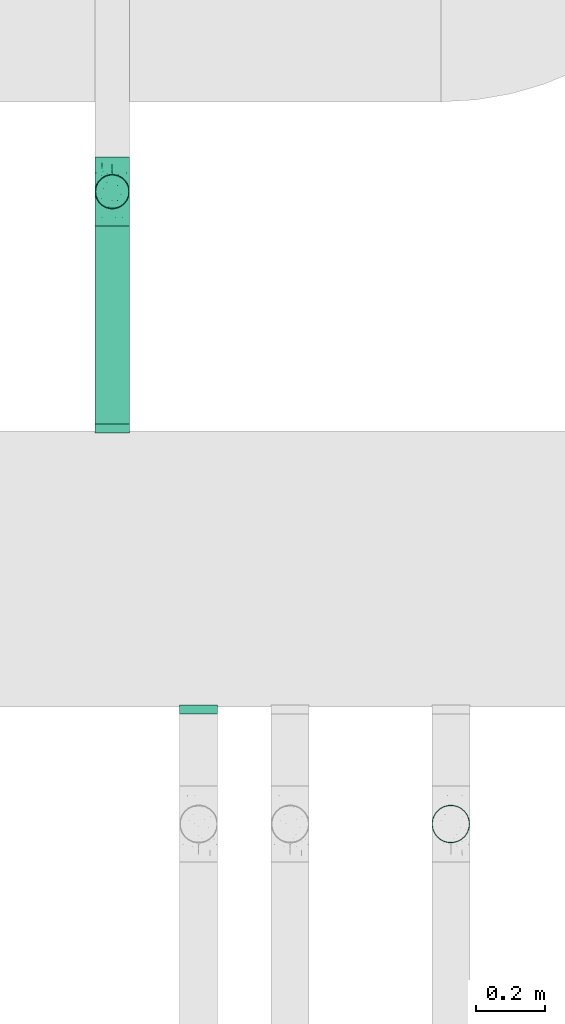
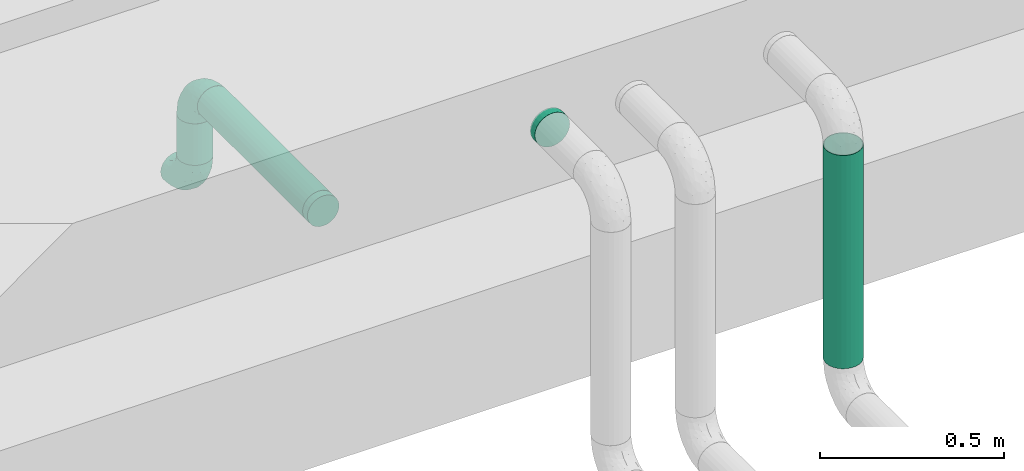
# One storey, part 57 of 91: 4 flow fittings, 3 flow segments.
"""IFC2X3 building model written with IfcOpenShell, lengths in millimetres."""

import ifcopenshell
import ifcopenshell.guid

model = None  # the IFC model being written
_history = None  # IfcOwnerHistory: only IFC2X3 demands one
_inside = {}  # id of a spatial element -> (the spatial element, [elements in it])
_under = {}  # id of a project, library or spatial element -> (it, [spatial elements below it])
_declared = {}  # id of a project -> (the project, [libraries it declares])
_typed = {}  # id of a type object -> (the type object, [elements of that type])
_made_of = {}  # id of a material, layer set ... -> (it, [elements and type objects made of it])


def new_model(schema):
    """Start an empty IFC model of exactly this schema.

    Asked for "IFC4X3", IfcOpenShell would pick the latest addendum, in which some entities
    have other attributes; the version numbers below select the first issue.
    IFC2X3 requires an IfcOwnerHistory on every rooted entity: one is made here for all.
    """
    global model, _history
    if schema == "IFC4X3":
        model = ifcopenshell.file(schema_version=(4, 3, 0, 0))
    else:
        model = ifcopenshell.file(schema=schema)
    _inside.clear()
    _under.clear()
    _declared.clear()
    _typed.clear()
    _made_of.clear()
    _history = None
    if model.schema == "IFC2X3":
        org = make("IfcOrganization", Name="unknown")
        user = make(
            "IfcPersonAndOrganization",
            ThePerson=make("IfcPerson", FamilyName="unknown"),
            TheOrganization=org,
        )
        app = make(
            "IfcApplication",
            ApplicationDeveloper=org,
            Version="unknown",
            ApplicationFullName="unknown",
            ApplicationIdentifier="unknown",
        )
        _history = make(
            "IfcOwnerHistory",
            OwningUser=user,
            OwningApplication=app,
            ChangeAction="ADDED",
            CreationDate=0,
        )
    return model


def make(cls, **values):
    """One entity of the class cls with the attributes given. An attribute that is None is left unset."""
    return model.create_entity(
        cls, **{name: value for name, value in values.items() if value is not None}
    )


def entity(cls, *values):
    """Any entity or typed value of the class cls, its attributes in the order of the schema. None: left unset."""
    e = model.create_entity(cls)
    for i, value in enumerate(values):
        if value is not None:
            e[i] = value
    return e


def rooted(cls, **values):
    """An entity with a GlobalId (a new one), such as an element, a storey or a relation."""
    return make(cls, GlobalId=ifcopenshell.guid.new(), OwnerHistory=_history, **values)


def si_unit(unit_type, name, prefix=None):
    """IfcSIUnit, for example si_unit("LENGTHUNIT", "METRE", prefix="MILLI")."""
    return make("IfcSIUnit", UnitType=unit_type, Prefix=prefix, Name=name)


def converted_unit(unit_type, name, factor, base, dimensions=None, offset=None):
    """IfcConversionBasedUnit, such as the inch: factor (a typed value) times the base unit."""
    return make(
        "IfcConversionBasedUnit"
        if offset is None
        else "IfcConversionBasedUnitWithOffset",
        ConversionOffset=offset,
        Dimensions=None
        if dimensions is None
        else entity("IfcDimensionalExponents", *dimensions),
        UnitType=unit_type,
        Name=name,
        ConversionFactor=make(
            "IfcMeasureWithUnit", ValueComponent=factor, UnitComponent=base
        ),
    )


def derived_unit(unit_type, elements):
    """IfcDerivedUnit: a product of units, each with its exponent."""
    return make(
        "IfcDerivedUnit",
        Elements=[
            make("IfcDerivedUnitElement", Unit=unit, Exponent=power)
            for unit, power in elements
        ],
        UnitType=unit_type,
    )


def assignment(units):
    """IfcUnitAssignment: the units of a project."""
    return None if units is None else make("IfcUnitAssignment", Units=units)


def point(xyz):
    """IfcCartesianPoint."""
    return None if xyz is None else make("IfcCartesianPoint", Coordinates=xyz)


def direction(xyz):
    """IfcDirection."""
    return None if xyz is None else make("IfcDirection", DirectionRatios=xyz)


def frame(location, z_axis=None, x_axis=None):
    """IfcAxis2Placement3D, a coordinate frame: its origin and axes. An axis left out is left unset."""
    return make(
        "IfcAxis2Placement3D",
        Location=point(location),
        Axis=direction(z_axis),
        RefDirection=direction(x_axis),
    )


def frame_2d(location, x_axis=None):
    """IfcAxis2Placement2D, a coordinate frame in the plane: its origin and x axis."""
    return make(
        "IfcAxis2Placement2D", Location=point(location), RefDirection=direction(x_axis)
    )


def origin_with_axes():
    """The frame at (0, 0, 0) with the z axis (0, 0, 1) and the x axis (1, 0, 0) written out."""
    return frame((0.0, 0.0, 0.0), z_axis=(0.0, 0.0, 1.0), x_axis=(1.0, 0.0, 0.0))


def origin_2d_with_axis():
    """The frame at (0, 0) in the plane with the x axis (1, 0) written out."""
    return frame_2d((0.0, 0.0), x_axis=(1.0, 0.0))


def place(relative_to, where):
    """IfcLocalPlacement: puts the frame where relative to a parent placement (None: the world)."""
    return make(
        "IfcLocalPlacement", PlacementRelTo=relative_to, RelativePlacement=where
    )


def context(
    kind, dimensions, precision=None, world=None, true_north=None, identifier=None
):
    """IfcGeometricRepresentationContext, for example the 3D "Model" context."""
    return make(
        "IfcGeometricRepresentationContext",
        ContextIdentifier=identifier,
        ContextType=kind,
        CoordinateSpaceDimension=dimensions,
        Precision=precision,
        WorldCoordinateSystem=world,
        TrueNorth=true_north,
    )


def subcontext(parent, identifier, kind, view, scale=None):
    """IfcGeometricRepresentationSubContext, for example "Body" below "Model"."""
    return make(
        "IfcGeometricRepresentationSubContext",
        ContextIdentifier=identifier,
        ContextType=kind,
        ParentContext=parent,
        TargetScale=scale,
        TargetView=view,
    )


def project(units=None, contexts=None):
    """IfcProject with its units and contexts."""
    return rooted(
        "IfcProject",
        Name="project",
        RepresentationContexts=contexts,
        UnitsInContext=assignment(units),
    )


def spatial(cls, under=None, at=None, **own):
    """A site, building, storey or space (cls), placed at a placement, below another one or the project."""
    s = rooted(cls, ObjectPlacement=at, **own)
    if under is not None:
        _under.setdefault(under.id(), (under, []))[1].append(s)
    return s


def profile(cls, at=None, kind="AREA", **sizes):
    """A parametric profile (cls). Its sizes go by their IFC names, for example OverallWidth=200.0."""
    return make(cls, ProfileType=kind, Position=at, **sizes)


def hollow_circle(**sizes):
    """IfcCircleHollowProfileDef."""
    return profile("IfcCircleHollowProfileDef", **sizes)


def extrude(swept, where, along, depth):
    """IfcExtrudedAreaSolid: the profile swept, set in the frame where, extruded along a direction by depth."""
    return make(
        "IfcExtrudedAreaSolid",
        SweptArea=swept,
        Position=where,
        ExtrudedDirection=direction(along),
        Depth=depth,
    )


def faces_of(points, faces, orient=None, outer=None):
    """IfcFace entities. A face is a list of loops; a loop is a list of indices into points, from 0.

    orient and outer hold one flag for each loop. By default every Orientation is true, the
    first loop of a face is its IfcFaceOuterBound and the others are IfcFaceBound.
    """
    made = []
    for i, loops in enumerate(faces):
        bounds = []
        for j, loop in enumerate(loops):
            is_outer = j == 0 if outer is None else outer[i][j]
            bounds.append(
                make(
                    "IfcFaceOuterBound" if is_outer else "IfcFaceBound",
                    Bound=make("IfcPolyLoop", Polygon=[points[k] for k in loop]),
                    Orientation=True if orient is None else orient[i][j],
                )
            )
        made.append(make("IfcFace", Bounds=bounds))
    return made


def open_shell(faces, orient=None, outer=None):
    """The faces of one IfcOpenShell. surface_model builds it on its shared points."""
    return ("IfcOpenShell", faces, orient, outer)


def surface_model(cls, points, shells):
    """IfcFaceBasedSurfaceModel or IfcShellBasedSurfaceModel (cls): surfaces that need not close."""
    shared = [point(p) for p in points]
    made = [make(c, CfsFaces=faces_of(shared, fs, o, b)) for c, fs, o, b in shells]
    if cls == "IfcFaceBasedSurfaceModel":
        return make(cls, FbsmFaces=made)
    return make(cls, SbsmBoundary=made)


def shape(context_of_items, identifier, shape_type, items):
    """IfcShapeRepresentation: the items that make up one representation, for example the "Body"."""
    return make(
        "IfcShapeRepresentation",
        ContextOfItems=context_of_items,
        RepresentationIdentifier=identifier,
        RepresentationType=shape_type,
        Items=items,
    )


def source(mapping_origin, context_of_items, identifier, shape_type, items):
    """IfcRepresentationMap: a shape defined once, which mapped items show again and again."""
    return make(
        "IfcRepresentationMap",
        MappingOrigin=mapping_origin,
        MappedRepresentation=shape(context_of_items, identifier, shape_type, items),
    )


def transform(
    local_origin,
    x_axis=None,
    y_axis=None,
    z_axis=None,
    scale=None,
    scale2=None,
    scale3=None,
    uniform=True,
):
    """IfcCartesianTransformationOperator3D, or its non-uniform kind. x_axis, y_axis, z_axis: its Axis1, 2, 3."""
    if uniform:
        return make(
            "IfcCartesianTransformationOperator3D",
            Axis1=direction(x_axis),
            Axis2=direction(y_axis),
            LocalOrigin=point(local_origin),
            Scale=scale,
            Axis3=direction(z_axis),
        )
    return make(
        "IfcCartesianTransformationOperator3DnonUniform",
        Axis1=direction(x_axis),
        Axis2=direction(y_axis),
        LocalOrigin=point(local_origin),
        Scale=scale,
        Axis3=direction(z_axis),
        Scale2=scale2,
        Scale3=scale3,
    )


def mapped(mapping_source, mapping_target):
    """IfcMappedItem: shows the shape of a source again, moved by a transform."""
    return make(
        "IfcMappedItem", MappingSource=mapping_source, MappingTarget=mapping_target
    )


def material(Name=None, Category=None):
    """IfcMaterial."""
    return make("IfcMaterial", Name=Name, Category=Category)


def layer(
    of_material, thickness, ventilated=None, Name=None, Category=None, Priority=None
):
    """IfcMaterialLayer: one layer of a wall or slab, of a material (None: an air gap)."""
    return make(
        "IfcMaterialLayer",
        Material=of_material,
        LayerThickness=thickness,
        IsVentilated=ventilated,
        Name=Name,
        Category=Category,
        Priority=Priority,
    )


def layer_set(layers, Name=None):
    """IfcMaterialLayerSet."""
    return make("IfcMaterialLayerSet", MaterialLayers=layers, LayerSetName=Name)


def layer_usage(for_layer_set, set_direction, sense, offset, extent=None):
    """IfcMaterialLayerSetUsage: how a layer set lies in its element."""
    return make(
        "IfcMaterialLayerSetUsage",
        ForLayerSet=for_layer_set,
        LayerSetDirection=set_direction,
        DirectionSense=sense,
        OffsetFromReferenceLine=offset,
        ReferenceExtent=extent,
    )


def made_of(thing, what):
    """Note that an element or type object is made of a material, layer set ...; save() writes the relation."""
    if what is not None:
        _made_of.setdefault(what.id(), (what, []))[1].append(thing)
    return thing


def type_object(cls, material=None, **own):
    """A type object (cls), such as IfcWallType, which elements share."""
    return made_of(rooted(cls, **own), material)


def element(
    cls,
    number,
    at=None,
    inside=None,
    cuts=None,
    type_object=None,
    material=None,
    context=None,
    identifier="Body",
    shape_type=None,
    held_by="IfcProductDefinitionShape",
    body=None,
    shapes=None,
    **own,
):
    """One element of the class cls, such as IfcWall. Its Tag is "e" and its number.

    at: its placement. inside: the storey or other place that contains it. cuts: it is an
    opening in that element (IfcRelVoidsElement). A single representation is given by context,
    identifier, shape_type and body (its items); several are given by shapes. held_by: the class
    of the entity that holds the representations. save() writes the other relations.
    """
    e = rooted(cls, Tag="e%d" % number, ObjectPlacement=at, **own)
    if body is not None:
        shapes = [shape(context, identifier, shape_type, body)]
    if shapes is not None:
        e.Representation = make(held_by, Representations=shapes)
    if inside is not None:
        _inside.setdefault(inside.id(), (inside, []))[1].append(e)
    if cuts is not None:
        rooted(
            "IfcRelVoidsElement", RelatingBuildingElement=cuts, RelatedOpeningElement=e
        )
    if type_object is not None:
        _typed.setdefault(type_object.id(), (type_object, []))[1].append(e)
    return made_of(e, material)


def aggregate(whole, parts):
    """IfcRelAggregates: a whole, such as a stair, and the parts it consists of."""
    return rooted("IfcRelAggregates", RelatingObject=whole, RelatedObjects=parts)


def save(model, path):
    """Write the relations noted so far, then the file.

    IfcRelAggregates (storeys below a building ...), IfcRelContainedInSpatialStructure (elements
    in a storey), IfcRelDefinesByType, IfcRelAssociatesMaterial and IfcRelDeclares: one each for
    every whole, place, type object, material and project.
    """
    for whole, parts in _under.values():
        aggregate(whole, parts)
    for where, things in _inside.values():
        rooted(
            "IfcRelContainedInSpatialStructure",
            RelatedElements=things,
            RelatingStructure=where,
        )
    for kind, things in _typed.values():
        rooted("IfcRelDefinesByType", RelatedObjects=things, RelatingType=kind)
    for what, things in _made_of.values():
        rooted("IfcRelAssociatesMaterial", RelatedObjects=things, RelatingMaterial=what)
    for by, libraries in _declared.values():
        rooted("IfcRelDeclares", RelatingContext=by, RelatedDefinitions=libraries)
    model.write(path)


model = new_model("IFC2X3")

# Units and contexts
model_context = context("Model", 3, precision=1e-05, world=origin_with_axes(), true_north=direction((0.0, 1.0)))
body_context = subcontext(model_context, "Body", "Model", "MODEL_VIEW")
ifc_project = project(units=[si_unit("AREAUNIT", "SQUARE_METRE"), si_unit("VOLUMEUNIT", "CUBIC_METRE", prefix="DECI"), si_unit("TIMEUNIT", "SECOND"), si_unit("THERMODYNAMICTEMPERATUREUNIT", "DEGREE_CELSIUS"), si_unit("PRESSUREUNIT", "PASCAL"), si_unit("MASSUNIT", "GRAM", prefix="KILO"), si_unit("LENGTHUNIT", "METRE", prefix="MILLI"), si_unit("POWERUNIT", "WATT"), si_unit("ELECTRICCURRENTUNIT", "AMPERE"), si_unit("ELECTRICVOLTAGEUNIT", "VOLT"), derived_unit("VOLUMETRICFLOWRATEUNIT", [(si_unit("VOLUMEUNIT", "CUBIC_METRE", prefix="DECI"), 1), (si_unit("TIMEUNIT", "SECOND"), -1)]), derived_unit("LINEARVELOCITYUNIT", [(si_unit("LENGTHUNIT", "METRE"), 1), (si_unit("TIMEUNIT", "SECOND"), -1)]), derived_unit("MASSDENSITYUNIT", [(si_unit("MASSUNIT", "GRAM", prefix="KILO"), 1), (si_unit("VOLUMEUNIT", "CUBIC_METRE"), -1)]), converted_unit("PLANEANGLEUNIT", "DEGREE", entity("IfcRatioMeasure", 0.01745), si_unit("PLANEANGLEUNIT", "RADIAN"), dimensions=[0, 0, 0, 0, 0, 0, 0])], contexts=[model_context])

# Site, building, storey
site_placement = place(None, origin_with_axes())
site = spatial("IfcSite", under=ifc_project, at=site_placement, CompositionType="ELEMENT")
building_placement = place(site_placement, origin_with_axes())
building = spatial("IfcBuilding", under=site, at=building_placement, Name="mc-building", CompositionType="ELEMENT")
storey_placement = place(building_placement, frame((0.0, 0.0, 8700.0), z_axis=(0.0, 0.0, 1.0), x_axis=(1.0, 0.0, 0.0)))
storey = spatial("IfcBuildingStorey", under=building, at=storey_placement, CompositionType="ELEMENT", Elevation=8700.0)

# Flow fittings
duct_fitting_type_1 = type_object("IfcDuctFittingType", Name="BU", PredefinedType="BEND")
shared_shape_1 = source(origin_with_axes(), body_context, "Body", "SurfaceModel", [
    surface_model("IfcShellBasedSurfaceModel", [(-100.0, 0.0, -50.0), (-100.0, -12.94095, -48.29629), (-100.0, 12.94095, -48.29629), (-100.0, 48.29629, 12.94095), (-100.0, 25.0, -43.30127), (-100.0, 43.30127, -25.0), (-100.0, 35.35534, -35.35534), (-100.0, -50.0, 0.0), (-100.0, -48.29629, 12.94095), (-100.0, -35.35534, -35.35534), (-100.0, -25.0, -43.30127), (-100.0, -48.29629, -12.94095), (-100.0, -43.30127, -25.0), (-100.0, 48.29629, -12.94095), (-100.0, 43.30127, 25.0), (-100.0, 35.35534, 35.35534), (-100.0, -12.94095, 48.29629), (-100.0, 25.0, 43.30127), (-100.0, 12.94095, 48.29629), (-100.0, -43.30127, 25.0), (-100.0, -35.35534, 35.35534), (-100.0, -25.0, 43.30127), (-100.0, 0.0, 50.0), (-100.0, 50.0, 0.0), (-12.94095, 100.0, -48.29629), (-50.0, 100.0, 0.0), (0.0, 100.0, -50.0), (-25.0, 100.0, -43.30127), (-35.35534, 100.0, -35.35534), (-43.30127, 100.0, -25.0), (35.35534, 100.0, -35.35534), (48.29629, 100.0, 12.94095), (25.0, 100.0, -43.30127), (12.94095, 100.0, -48.29629), (43.30127, 100.0, -25.0), (48.29629, 100.0, -12.94095), (50.0, 100.0, 0.0), (-48.29629, 100.0, -12.94095), (-48.29629, 100.0, 12.94095), (-43.30127, 100.0, 25.0), (-35.35534, 100.0, 35.35534), (0.0, 100.0, 50.0), (-25.0, 100.0, 43.30127), (-12.94095, 100.0, 48.29629), (43.30127, 100.0, 25.0), (35.35534, 100.0, 35.35534), (25.0, 100.0, 43.30127), (12.94095, 100.0, 48.29629), (-58.37939, 44.26324, 39.66767), (-69.67318, 34.70921, 41.41807), (-54.95374, 29.60867, 47.22379), (-69.0983, 4.89435, 50.0), (-81.95957, 10.85813, 49.17398), (-71.45436, 24.34004, 46.19398), (-63.80701, 16.86512, 49.12211), (-68.68567, 49.28345, 29.46598), (-84.79657, 41.61468, 30.43807), (-87.38486, 20.12422, 46.19398), (-19.0983, 41.22148, 50.0), (-16.69326, 64.07661, 49.13167), (-29.12893, 54.21835, 47.49497), (-58.07867, 67.98053, 16.35576), (-67.87621, 57.34916, 18.11021), (-57.82431, 60.07162, 27.24983), (-90.54273, 47.92896, 16.84479), (-84.64671, 51.44953, 9.54872), (-89.28706, 52.13093, 0.0), (-48.57141, 84.18266, 19.13417), (-80.49866, 49.85236, 19.13417), (-10.78328, 82.03604, 49.18466), (-4.89435, 69.0983, 50.0), (-52.13093, 89.28706, 0.0), (-51.49654, 84.66157, 9.29171), (-41.22148, 19.0983, 50.0), (-40.55308, 40.55308, 47.39468), (-84.25895, 32.24248, 39.66767), (-20.22969, 86.73423, 46.19398), (-32.70712, 82.37816, 39.66767), (-39.73574, 63.26064, 40.42863), (-24.76101, 70.36257, 46.19398), (-52.07527, 72.10209, 22.70672), (-53.34351, 76.64659, 14.58596), (-75.39343, 54.87419, 11.74349), (-45.34852, 49.56196, 42.93091), (-67.79776, 60.76145, 8.68857), (-41.23466, 86.33892, 30.43807), (-53.80602, 80.86583, 0.0), (-46.83364, 71.48109, 30.43807), (-59.22534, 72.75524, 0.0), (-51.32111, 56.42251, 36.03223), (-80.86583, 53.80602, 0.0), (-64.64466, 64.64466, 0.0), (-72.75524, 59.22534, 0.0), (-86.30081, 41.24353, -30.43807), (-84.6487, 51.45583, -9.51467), (-90.59087, 47.99544, -16.6365), (-82.00387, 32.80624, -39.66767), (-72.72667, 42.3343, -34.47953), (-69.0983, 4.89435, -50.0), (-66.13967, 17.89682, -48.73206), (-41.22148, 19.0983, -50.0), (-19.92688, 59.20071, -48.9627), (-4.89435, 69.0983, -50.0), (-19.0983, 41.22148, -50.0), (-32.19887, 84.44786, -39.66767), (-82.82099, 10.02515, -49.28938), (-41.61468, 84.79657, -30.43807), (-82.27704, 21.1002, -46.19398), (-64.48049, 30.28903, -45.01594), (-71.3903, 57.59661, -10.6727), (-22.65007, 76.4146, -46.19398), (-80.71765, 49.76775, -19.13417), (-63.27201, 52.13514, -30.43807), (-66.69474, 56.78794, -20.8562), (-57.71875, 61.44646, -25.88117), (-51.44953, 84.64671, -9.54872), (-49.85236, 80.49866, -19.13417), (-49.18799, 68.95983, -29.38061), (-52.50869, 28.2692, -48.00802), (-47.92896, 90.54273, -16.84479), (-11.48103, 81.33005, -49.0827), (-31.33477, 60.4193, -45.4939), (-39.98518, 39.98518, -47.65708), (-59.80479, 65.98498, -16.07996), (-63.94971, 39.6845, -40.19955), (-52.24546, 47.26788, -40.83149), (-55.20497, 74.81068, -11.71424), (-38.49923, 67.49589, -39.66767), (-52.04722, 57.72873, -34.6201), (-73.59404, 48.69992, -26.65479), (-47.57173, 4.1387, -49.13473), (29.5722, 42.84907, -27.71428), (13.52969, 19.02651, -30.72245), (13.59601, 32.77977, -38.42312), (27.49134, 63.71843, -37.951), (17.59627, 59.41659, -43.64098), (-63.95523, -42.22253, -17.81382), (-42.84907, -29.5722, -27.71428), (-25.90272, -27.798, -14.9099), (-4.1387, 47.57173, -49.13473), (-20.45037, 20.45037, -48.41225), (-68.61243, -10.20497, -47.82471), (-73.92917, -46.87327, -9.07697), (-73.47057, -38.0442, -29.22414), (-63.71843, -27.49134, -37.951), (-32.77977, -13.59601, -38.42312), (-8.32573, -9.86545, -25.36336), (-59.41659, -17.59627, -43.64098), (10.20497, 68.61244, -47.82471), (3.58524, 39.93936, -45.93923), (-12.17948, 12.17948, -43.75507), (-39.93936, -3.58524, -45.93923), (44.88888, 61.17714, 0.0), (38.05536, 43.47505, -9.02401), (45.64165, 67.74269, -9.06645), (17.21028, 10.65055, -15.96581), (-25.0, -29.90381, 0.0), (-1.12135, -11.13977, -11.07369), (38.0442, 73.47057, -29.22414), (32.46004, 37.55825, -18.52941), (42.22253, 63.95523, -17.81382), (29.90381, 25.0, 0.0), (6.06602, -6.06602, 0.0), (-61.17714, -44.88888, 0.0), (-45.78423, -39.05041, -8.65056), (-4.97501, 4.97501, -36.29915), (-63.95523, -42.22253, 17.81382), (-67.74269, -45.64165, 9.06645), (-37.55825, -32.46004, 18.52941), (-42.84907, -29.5722, 27.71428), (-73.47057, -38.0442, 29.22414), (-4.1387, 47.57173, 49.13473), (10.20497, 68.61244, 47.82471), (-39.93936, -3.58524, 45.93923), (-59.41659, -17.59627, 43.64098), (-32.77977, -13.59601, 38.42312), (-63.71843, -27.49134, 37.951), (-10.65055, -17.21028, 15.96581), (27.798, 25.90272, 14.9099), (11.13977, 1.12135, 11.07369), (46.87327, 73.92917, 9.07697), (39.05041, 45.78423, 8.65056), (-68.61243, -10.20497, 47.82471), (-47.57173, 4.1387, 49.13473), (3.58524, 39.93936, 45.93923), (-20.45037, 20.45037, 48.41225), (-12.17948, 12.17948, 43.75507), (9.86545, 8.32574, 25.36336), (-19.02651, -13.52969, 30.72245), (-43.47505, -38.05536, 9.02401), (29.5722, 42.84907, 27.71428), (42.22253, 63.95523, 17.81382), (38.0442, 73.47057, 29.22414), (27.49134, 63.71843, 37.951), (17.59627, 59.41659, 43.64098), (13.59601, 32.77977, 38.42312), (-4.97501, 4.97501, 36.29915)], [open_shell([[[0, 1, 2]], [[2, 3, 4]], [[5, 6, 3]], [[3, 6, 4]], [[2, 7, 8]], [[9, 7, 10]], [[1, 10, 7]], [[11, 7, 12]], [[9, 12, 7]], [[7, 2, 1]], [[13, 5, 3]], [[14, 3, 2]], [[15, 14, 2]], [[16, 17, 2]], [[15, 2, 17]], [[18, 17, 16]], [[8, 19, 2]], [[2, 19, 20]], [[2, 20, 21]], [[16, 2, 21]], [[16, 22, 18]], [[23, 13, 3]], [[24, 25, 26]], [[27, 25, 24]], [[25, 28, 29]], [[27, 28, 25]], [[30, 26, 31]], [[26, 30, 32]], [[32, 33, 26]], [[30, 31, 34]], [[35, 34, 31]], [[35, 31, 36]], [[37, 25, 29]], [[26, 38, 39]], [[26, 39, 40]], [[41, 40, 42]], [[40, 41, 26]], [[41, 42, 43]], [[26, 44, 31]], [[45, 44, 26]], [[46, 45, 26]], [[47, 46, 26]], [[47, 26, 41]], [[26, 25, 38]], [[48, 49, 50]], [[22, 51, 52]], [[53, 54, 50]], [[55, 56, 49]], [[56, 14, 15]], [[18, 57, 17]], [[58, 59, 60]], [[61, 62, 63]], [[3, 64, 65]], [[53, 52, 54]], [[3, 65, 66]], [[67, 39, 38]], [[56, 68, 64]], [[65, 64, 68]], [[69, 59, 70]], [[38, 71, 72]], [[73, 58, 74]], [[75, 49, 56]], [[76, 69, 43]], [[53, 57, 52]], [[77, 78, 79]], [[42, 76, 43]], [[43, 69, 41]], [[55, 68, 56]], [[15, 17, 75]], [[76, 77, 79]], [[80, 67, 81]], [[62, 82, 68]], [[60, 78, 83]], [[62, 84, 82]], [[85, 77, 40]], [[81, 67, 72]], [[86, 72, 71]], [[87, 85, 67]], [[61, 81, 88]], [[77, 42, 40]], [[78, 77, 87]], [[15, 75, 56]], [[83, 89, 48]], [[85, 40, 39]], [[62, 68, 55]], [[89, 87, 63]], [[83, 48, 50]], [[57, 75, 17]], [[49, 75, 53]], [[67, 85, 39]], [[87, 77, 85]], [[63, 62, 55]], [[89, 55, 48]], [[80, 63, 87]], [[66, 65, 90]], [[66, 23, 3]], [[84, 91, 92]], [[92, 90, 82]], [[65, 82, 90]], [[61, 84, 62]], [[92, 82, 84]], [[68, 82, 65]], [[3, 14, 64]], [[56, 64, 14]], [[38, 25, 71]], [[81, 72, 86]], [[38, 72, 67]], [[91, 61, 88]], [[80, 81, 61]], [[63, 80, 61]], [[67, 80, 87]], [[77, 76, 42]], [[79, 59, 69]], [[79, 69, 76]], [[41, 69, 70]], [[60, 59, 79]], [[58, 70, 59]], [[78, 60, 79]], [[58, 60, 74]], [[52, 57, 18]], [[75, 57, 53]], [[22, 52, 18]], [[52, 51, 54]], [[51, 73, 54]], [[50, 73, 74]], [[73, 50, 54]], [[50, 74, 83]], [[60, 83, 74]], [[89, 83, 78]], [[87, 89, 78]], [[55, 89, 63]], [[50, 49, 53]], [[55, 49, 48]], [[81, 86, 88]], [[91, 84, 61]], [[6, 5, 93]], [[90, 94, 66]], [[13, 94, 95]], [[96, 93, 97]], [[98, 99, 100]], [[96, 4, 6]], [[101, 102, 103]], [[28, 27, 104]], [[2, 105, 0]], [[104, 106, 28]], [[99, 105, 107]], [[108, 107, 96]], [[90, 109, 94]], [[107, 2, 4]], [[13, 66, 94]], [[27, 24, 110]], [[109, 111, 94]], [[112, 113, 114]], [[37, 115, 71]], [[116, 106, 117]], [[99, 118, 100]], [[116, 115, 119]], [[37, 119, 115]], [[24, 120, 110]], [[121, 110, 101]], [[119, 106, 116]], [[101, 110, 120]], [[122, 103, 100]], [[117, 123, 116]], [[124, 125, 108]], [[115, 116, 126]], [[106, 29, 28]], [[26, 102, 120]], [[127, 104, 110]], [[97, 124, 96]], [[125, 122, 118]], [[128, 127, 125]], [[96, 6, 93]], [[115, 126, 86]], [[117, 106, 127]], [[111, 113, 129]], [[95, 93, 5]], [[97, 129, 112]], [[110, 104, 27]], [[106, 104, 127]], [[96, 107, 4]], [[99, 107, 108]], [[99, 108, 118]], [[105, 99, 98]], [[112, 114, 128]], [[121, 125, 127]], [[13, 23, 66]], [[109, 90, 92]], [[94, 111, 95]], [[91, 123, 109]], [[129, 113, 112]], [[93, 95, 111]], [[5, 13, 95]], [[71, 115, 86]], [[71, 25, 37]], [[123, 91, 88]], [[126, 116, 123]], [[123, 88, 126]], [[86, 126, 88]], [[37, 29, 119]], [[106, 119, 29]], [[129, 93, 111]], [[124, 112, 125]], [[0, 105, 98]], [[107, 105, 2]], [[125, 118, 108]], [[100, 118, 122]], [[93, 129, 97]], [[113, 111, 109]], [[109, 123, 113]], [[114, 123, 117]], [[123, 114, 113]], [[128, 114, 117]], [[127, 128, 117]], [[112, 128, 125]], [[103, 122, 101]], [[110, 121, 127]], [[101, 122, 121]], [[125, 121, 122]], [[26, 120, 24]], [[101, 120, 102]], [[96, 124, 108]], [[92, 91, 109]], [[112, 124, 97]], [[100, 130, 98]], [[131, 132, 133]], [[32, 134, 135]], [[136, 137, 138]], [[139, 140, 103]], [[98, 141, 0]], [[142, 11, 136]], [[143, 144, 137]], [[7, 11, 142]], [[137, 145, 146]], [[144, 147, 145]], [[143, 136, 12]], [[12, 136, 11]], [[9, 143, 12]], [[148, 149, 139]], [[9, 10, 144]], [[10, 1, 147]], [[130, 141, 98]], [[103, 140, 100]], [[148, 135, 149]], [[150, 151, 140]], [[152, 153, 154]], [[130, 140, 151]], [[148, 26, 33]], [[147, 1, 141]], [[155, 146, 132]], [[156, 138, 157]], [[134, 30, 158]], [[150, 140, 149]], [[158, 30, 34]], [[30, 134, 32]], [[153, 159, 160]], [[131, 160, 159]], [[144, 145, 137]], [[36, 152, 154]], [[146, 138, 137]], [[155, 161, 162]], [[158, 160, 131]], [[133, 149, 135]], [[156, 163, 164]], [[163, 142, 164]], [[139, 103, 102]], [[153, 152, 161]], [[34, 35, 160]], [[162, 157, 155]], [[132, 165, 133]], [[157, 146, 155]], [[140, 130, 100]], [[141, 130, 151]], [[141, 151, 147]], [[141, 1, 0]], [[102, 26, 148]], [[140, 139, 149]], [[102, 148, 139]], [[135, 33, 32]], [[151, 150, 145]], [[10, 147, 144]], [[151, 145, 147]], [[145, 165, 146]], [[135, 148, 33]], [[133, 135, 134]], [[131, 133, 134]], [[133, 165, 150]], [[133, 150, 149]], [[145, 150, 165]], [[132, 131, 159]], [[146, 165, 132]], [[160, 158, 34]], [[134, 158, 131]], [[144, 143, 9]], [[136, 143, 137]], [[155, 153, 161]], [[154, 153, 160]], [[153, 155, 159]], [[132, 159, 155]], [[160, 35, 154]], [[36, 154, 35]], [[164, 136, 138]], [[7, 142, 163]], [[136, 164, 142]], [[156, 164, 138]], [[156, 157, 162]], [[146, 157, 138]], [[19, 8, 166]], [[7, 163, 167]], [[168, 169, 166]], [[166, 169, 170]], [[171, 172, 70]], [[173, 174, 175]], [[21, 176, 174]], [[177, 156, 162]], [[176, 20, 170]], [[170, 20, 19]], [[161, 178, 179]], [[152, 180, 181]], [[182, 173, 183]], [[22, 16, 182]], [[184, 185, 186]], [[183, 185, 73]], [[183, 73, 51]], [[177, 187, 188]], [[189, 168, 166]], [[187, 178, 190]], [[20, 176, 21]], [[161, 152, 181]], [[44, 191, 31]], [[44, 45, 192]], [[192, 191, 44]], [[180, 36, 31]], [[193, 194, 195]], [[46, 47, 194]], [[193, 195, 190]], [[193, 45, 46]], [[172, 41, 70]], [[185, 58, 73]], [[189, 163, 156]], [[163, 189, 167]], [[70, 58, 171]], [[184, 171, 185]], [[169, 188, 175]], [[180, 31, 191]], [[192, 193, 190]], [[191, 190, 178]], [[182, 174, 173]], [[194, 47, 172]], [[190, 195, 187]], [[186, 185, 173]], [[162, 179, 177]], [[188, 196, 175]], [[179, 187, 177]], [[185, 171, 58]], [[172, 171, 184]], [[172, 184, 194]], [[172, 47, 41]], [[51, 22, 182]], [[185, 183, 173]], [[51, 182, 183]], [[174, 16, 21]], [[184, 186, 195]], [[46, 194, 193]], [[184, 195, 194]], [[195, 196, 187]], [[174, 182, 16]], [[175, 174, 176]], [[169, 175, 176]], [[175, 196, 186]], [[175, 186, 173]], [[195, 186, 196]], [[188, 169, 168]], [[187, 196, 188]], [[166, 170, 19]], [[176, 170, 169]], [[193, 192, 45]], [[191, 192, 190]], [[177, 189, 156]], [[167, 189, 166]], [[189, 177, 168]], [[188, 168, 177]], [[166, 8, 167]], [[7, 167, 8]], [[181, 191, 178]], [[36, 180, 152]], [[191, 181, 180]], [[161, 181, 178]], [[161, 179, 162]], [[187, 179, 178]]])]),
])
for number, where, z_axis, x_axis, name in (
    (1, (29537.7081, 4444.20513, 668.0), (1.0, 0.0, 0.0), (0.0, 0.0, 1.0), "BU"),
    (2, (29537.7081, 4444.20513, 330.23331), (-1.0, 0.0, 0.0), (0.0, -1.0, 0.0), "BU"),
):
    element("IfcFlowFitting", number, at=place(storey_placement, frame(where, z_axis=z_axis, x_axis=x_axis)), inside=storey, type_object=duct_fitting_type_1, Name=name, context=body_context, shape_type="MappedRepresentation", body=[
        mapped(shared_shape_1, transform((0.0, 0.0, 0.0), scale=1.0)),
    ])

# Flow segments
ifc_material = material(Name="FZ1")
ifc_layer = layer(ifc_material, 0.0)
ifc_layer_set = layer_set([ifc_layer], Name="FZ1")
ifc_layer_usage = layer_usage(ifc_layer_set, "AXIS1", "POSITIVE", 0.0)
duct_segment_type = type_object("IfcDuctSegmentType", PredefinedType="RIGIDSEGMENT")
shared_shape_2 = source(origin_with_axes(), body_context, "Body", "SweptSolid", [
    extrude(hollow_circle(Radius=50.0, WallThickness=2.0, at=origin_2d_with_axis()), frame((0.0, 0.0, 0.0), z_axis=(1.0, 0.0, 0.0), x_axis=(0.0, 1.0, 0.0)), (0.0, 0.0, 1.0), 573.0),
])
flow_segment_1_placement = place(storey_placement, frame((29537.7081, 4344.20513, 668.0), z_axis=(0.0, 0.0, 1.0), x_axis=(0.0, -1.0, 0.0)))
element("IfcFlowSegment", 3, at=flow_segment_1_placement, inside=storey, type_object=duct_segment_type, material=ifc_layer_usage, context=body_context, shape_type="MappedRepresentation", body=[
    mapped(shared_shape_2, transform((0.0, 0.0, 0.0), scale=1.0)),
])
shared_shape_3 = source(origin_with_axes(), body_context, "Body", "SweptSolid", [
    extrude(hollow_circle(Radius=55.0, WallThickness=2.0, at=origin_2d_with_axis()), frame((0.0, 0.0, 0.0), z_axis=(1.0, 0.0, 0.0), x_axis=(0.0, 1.0, 0.0)), (0.0, 0.0, 1.0), 709.0),
])
flow_segment_2_placement = place(storey_placement, frame((30518.54047, 2612.35324, 525.0), z_axis=(0.0, 1.0, 0.0), x_axis=(0.0, 0.0, 1.0)))
element("IfcFlowSegment", 4, at=flow_segment_2_placement, inside=storey, type_object=duct_segment_type, material=ifc_layer_usage, context=body_context, shape_type="MappedRepresentation", body=[
    mapped(shared_shape_3, transform((0.0, 0.0, 0.0), scale=1.0)),
])

# Flow fittings
duct_fitting_type_2 = type_object("IfcDuctFittingType", Name="CC", PredefinedType="CONNECTOR")
shared_shape_4 = source(origin_with_axes(), body_context, "Body", "SurfaceModel", [
    surface_model("IfcShellBasedSurfaceModel", [(-6.096, -12.94095, -48.29629), (-6.096, -50.0, 0.0), (-6.096, 0.0, -50.0), (-6.096, -25.0, -43.30127), (-6.096, -35.35534, -35.35534), (-6.096, -43.30127, -25.0), (-6.096, 35.35534, -35.35534), (-6.096, 48.29629, 12.94095), (-6.096, 25.0, -43.30127), (-6.096, 12.94095, -48.29629), (-6.096, 43.30127, -25.0), (-6.096, 48.29629, -12.94095), (-6.096, 50.0, 0.0), (-6.096, -48.29629, -12.94095), (-6.096, -48.29629, 12.94095), (-6.096, -43.30127, 25.0), (-6.096, -35.35534, 35.35534), (-6.096, -25.0, 43.30127), (-6.096, 0.0, 50.0), (-6.096, -12.94095, 48.29629), (-6.096, 43.30127, 25.0), (-6.096, 35.35534, 35.35534), (-6.096, 25.0, 43.30127), (-6.096, 12.94095, 48.29629), (0.0, -12.94095, 48.29629), (0.0, 0.0, 50.0), (0.0, -25.0, 43.30127), (0.0, -35.35534, 35.35534), (0.0, -48.29629, 12.94095), (0.0, -43.30127, 25.0), (0.0, -50.0, 0.0), (0.0, -48.29629, -12.94095), (0.0, -43.30127, -25.0), (0.0, -35.35534, -35.35534), (0.0, -12.94095, -48.29629), (0.0, -25.0, -43.30127), (0.0, 0.0, -50.0), (0.0, 12.94095, -48.29629), (0.0, 25.0, -43.30127), (0.0, 35.35534, -35.35534), (0.0, 48.29629, -12.94095), (0.0, 43.30127, -25.0), (0.0, 50.0, 0.0), (0.0, 48.29629, 12.94095), (0.0, 43.30127, 25.0), (0.0, 35.35534, 35.35534), (0.0, 12.94095, 48.29629), (0.0, 25.0, 43.30127), (20.0, 0.0, -50.0), (20.0, 12.94095, -48.29629), (20.0, -12.94095, -48.29629), (20.0, -48.29629, 12.94095), (20.0, -25.0, -43.30127), (20.0, -43.30127, -25.0), (20.0, -35.35534, -35.35534), (20.0, 50.0, 0.0), (20.0, 48.29629, 12.94095), (20.0, 35.35534, -35.35534), (20.0, 25.0, -43.30127), (20.0, 48.29629, -12.94095), (20.0, 43.30127, -25.0), (20.0, -48.29629, -12.94095), (20.0, -43.30127, 25.0), (20.0, -35.35534, 35.35534), (20.0, -25.0, 43.30127), (20.0, 12.94095, 48.29629), (20.0, -12.94095, 48.29629), (20.0, 43.30127, 25.0), (20.0, 35.35534, 35.35534), (20.0, 25.0, 43.30127), (20.0, 0.0, 50.0), (20.0, -50.0, 0.0)], [open_shell([[[0, 1, 2]], [[3, 1, 0]], [[1, 4, 5]], [[4, 1, 3]], [[6, 2, 7]], [[2, 6, 8]], [[8, 9, 2]], [[10, 7, 11]], [[7, 10, 6]], [[11, 7, 12]], [[5, 13, 1]], [[2, 14, 15]], [[2, 15, 16]], [[17, 18, 16]], [[18, 2, 16]], [[19, 18, 17]], [[2, 20, 7]], [[21, 20, 2]], [[22, 21, 2]], [[23, 22, 2]], [[23, 2, 18]], [[2, 1, 14]], [[24, 25, 18]], [[26, 24, 19]], [[19, 24, 18]], [[16, 27, 17]], [[26, 19, 17]], [[26, 17, 27]], [[28, 29, 15]], [[30, 28, 14]], [[15, 29, 16]], [[28, 15, 14]], [[30, 14, 1]], [[27, 16, 29]], [[31, 30, 1]], [[32, 31, 13]], [[13, 31, 1]], [[4, 33, 5]], [[32, 13, 5]], [[32, 5, 33]], [[34, 35, 3]], [[36, 34, 0]], [[3, 35, 4]], [[34, 3, 0]], [[36, 0, 2]], [[33, 4, 35]], [[37, 36, 2]], [[38, 37, 9]], [[9, 37, 2]], [[6, 39, 8]], [[38, 9, 8]], [[38, 8, 39]], [[40, 41, 10]], [[42, 40, 11]], [[10, 41, 6]], [[40, 10, 11]], [[42, 11, 12]], [[39, 6, 41]], [[43, 42, 12]], [[44, 43, 7]], [[7, 43, 12]], [[21, 45, 20]], [[44, 7, 20]], [[44, 20, 45]], [[46, 47, 22]], [[25, 46, 23]], [[22, 47, 21]], [[46, 22, 23]], [[25, 23, 18]], [[45, 21, 47]], [[48, 49, 50]], [[50, 51, 52]], [[53, 54, 51]], [[52, 51, 54]], [[50, 55, 56]], [[57, 55, 58]], [[49, 58, 55]], [[59, 55, 60]], [[57, 60, 55]], [[55, 50, 49]], [[53, 51, 61]], [[62, 51, 50]], [[63, 62, 50]], [[64, 50, 65]], [[64, 63, 50]], [[64, 65, 66]], [[56, 67, 50]], [[50, 67, 68]], [[50, 68, 69]], [[65, 50, 69]], [[65, 70, 66]], [[71, 61, 51]], [[66, 70, 25]], [[64, 66, 24]], [[24, 66, 25]], [[27, 63, 26]], [[64, 24, 26]], [[64, 26, 63]], [[51, 62, 29]], [[71, 51, 28]], [[29, 62, 27]], [[51, 29, 28]], [[71, 28, 30]], [[63, 27, 62]], [[61, 71, 30]], [[53, 61, 31]], [[31, 61, 30]], [[33, 54, 32]], [[53, 31, 32]], [[53, 32, 54]], [[50, 52, 35]], [[48, 50, 34]], [[35, 52, 33]], [[50, 35, 34]], [[48, 34, 36]], [[54, 33, 52]], [[49, 48, 36]], [[58, 49, 37]], [[37, 49, 36]], [[39, 57, 38]], [[58, 37, 38]], [[58, 38, 57]], [[59, 60, 41]], [[55, 59, 40]], [[41, 60, 39]], [[59, 41, 40]], [[55, 40, 42]], [[57, 39, 60]], [[56, 55, 42]], [[67, 56, 43]], [[43, 56, 42]], [[45, 68, 44]], [[67, 43, 44]], [[67, 44, 68]], [[65, 69, 47]], [[70, 65, 46]], [[47, 69, 45]], [[65, 47, 46]], [[70, 46, 25]], [[68, 45, 69]], [[50, 56, 67]], [[68, 69, 50]], [[18, 16, 17]], [[17, 19, 18]]])]),
])
flow_fitting_1_placement = place(storey_placement, frame((29537.7081, 3751.20513, 668.0), z_axis=(0.0, 0.0, -1.0), x_axis=(0.0, 1.0, 0.0)))
element("IfcFlowFitting", 5, at=flow_fitting_1_placement, inside=storey, type_object=duct_fitting_type_2, Name="CC", context=body_context, shape_type="MappedRepresentation", body=[
    mapped(shared_shape_4, transform((0.0, 0.0, 0.0), scale=1.0)),
])
shared_shape_5 = source(origin_with_axes(), body_context, "Body", "SurfaceModel", [
    surface_model("IfcShellBasedSurfaceModel", [(-6.096, -38.89087, -38.89087), (-6.096, -55.0, 0.0), (-6.096, -27.5, -47.63139), (-6.096, 47.63139, -27.5), (-6.096, 53.12592, 14.23505), (-6.096, 53.12592, -14.23505), (-6.096, 55.0, 0.0), (-6.096, -53.12592, -14.23505), (-6.096, -47.63139, -27.5), (20.0, 38.89087, -38.89087), (20.0, 55.0, 0.0), (20.0, 27.5, -47.63139), (20.0, 53.12592, -14.23505), (20.0, 47.63139, -27.5), (20.0, -47.63139, -27.5), (20.0, -53.12592, 14.23505), (20.0, -53.12592, -14.23505), (20.0, -55.0, 0.0), (-6.096, 0.0, -55.0), (-6.096, -14.23505, -53.12592), (-6.096, 14.23505, -53.12592), (-6.096, 27.5, -47.63139), (-6.096, 38.89087, -38.89087), (-6.096, -53.12592, 14.23505), (-6.096, 47.63139, 27.5), (-6.096, 38.89087, 38.89087), (-6.096, -14.23505, 53.12592), (-6.096, 27.5, 47.63139), (-6.096, 14.23505, 53.12592), (-6.096, -47.63139, 27.5), (-6.096, -38.89087, 38.89087), (-6.096, -27.5, 47.63139), (-6.096, 0.0, 55.0), (0.0, 0.0, 55.0), (0.0, 14.23505, 53.12592), (0.0, 27.5, 47.63139), (0.0, 38.89087, 38.89087), (0.0, 47.63139, 27.5), (0.0, 53.12592, 14.23505), (0.0, 55.0, 0.0), (0.0, 53.12592, -14.23505), (0.0, 47.63139, -27.5), (0.0, 38.89087, -38.89087), (0.0, 27.5, -47.63139), (0.0, 14.23505, -53.12592), (0.0, 0.0, -55.0), (0.0, -14.23505, -53.12592), (0.0, -27.5, -47.63139), (0.0, -38.89087, -38.89087), (0.0, -47.63139, -27.5), (0.0, -53.12592, -14.23505), (0.0, -55.0, 0.0), (0.0, -53.12592, 14.23505), (0.0, -47.63139, 27.5), (0.0, -38.89087, 38.89087), (0.0, -27.5, 47.63139), (0.0, -14.23505, 53.12592), (20.0, 0.0, -55.0), (20.0, 14.23505, -53.12592), (20.0, -38.89087, -38.89087), (20.0, -27.5, -47.63139), (20.0, -14.23505, -53.12592), (20.0, 53.12592, 14.23505), (20.0, 47.63139, 27.5), (20.0, 38.89087, 38.89087), (20.0, 0.0, 55.0), (20.0, 27.5, 47.63139), (20.0, 14.23505, 53.12592), (20.0, -38.89087, 38.89087), (20.0, -47.63139, 27.5), (20.0, -14.23505, 53.12592), (20.0, -27.5, 47.63139)], [open_shell([[[0, 1, 2]], [[3, 4, 5]], [[6, 5, 4]], [[7, 1, 8]], [[9, 10, 11]], [[12, 10, 13]], [[14, 15, 16]], [[17, 16, 15]], [[18, 19, 20]], [[20, 4, 21]], [[3, 22, 4]], [[21, 4, 22]], [[20, 1, 23]], [[19, 2, 1]], [[0, 8, 1]], [[1, 20, 19]], [[20, 24, 4]], [[25, 24, 20]], [[26, 27, 20]], [[27, 25, 20]], [[26, 28, 27]], [[20, 29, 30]], [[29, 20, 23]], [[30, 31, 20]], [[20, 31, 26]], [[26, 32, 28]], [[32, 33, 34]], [[28, 34, 35]], [[32, 34, 28]], [[27, 36, 25]], [[27, 28, 35]], [[36, 27, 35]], [[24, 37, 38]], [[4, 38, 39]], [[25, 37, 24]], [[4, 24, 38]], [[6, 4, 39]], [[37, 25, 36]], [[6, 39, 40]], [[5, 40, 41]], [[6, 40, 5]], [[3, 42, 22]], [[3, 5, 41]], [[42, 3, 41]], [[21, 43, 44]], [[20, 44, 45]], [[22, 43, 21]], [[20, 21, 44]], [[18, 20, 45]], [[43, 22, 42]], [[18, 45, 46]], [[19, 46, 47]], [[18, 46, 19]], [[2, 48, 0]], [[2, 19, 47]], [[48, 2, 47]], [[8, 49, 50]], [[7, 50, 51]], [[0, 49, 8]], [[7, 8, 50]], [[1, 7, 51]], [[49, 0, 48]], [[1, 51, 52]], [[23, 52, 53]], [[1, 52, 23]], [[29, 54, 30]], [[29, 23, 53]], [[54, 29, 53]], [[31, 55, 56]], [[26, 56, 33]], [[30, 55, 31]], [[26, 31, 56]], [[32, 26, 33]], [[55, 30, 54]], [[10, 57, 58]], [[11, 10, 58]], [[10, 9, 13]], [[59, 57, 15]], [[57, 59, 60]], [[60, 61, 57]], [[59, 15, 14]], [[62, 63, 57]], [[57, 63, 64]], [[65, 64, 66]], [[65, 57, 64]], [[67, 65, 66]], [[68, 69, 57]], [[15, 57, 69]], [[70, 71, 57]], [[71, 68, 57]], [[70, 57, 65]], [[10, 62, 57]], [[33, 65, 67]], [[34, 67, 66]], [[33, 67, 34]], [[35, 64, 36]], [[35, 34, 66]], [[64, 35, 66]], [[37, 63, 62]], [[38, 62, 10]], [[36, 63, 37]], [[38, 37, 62]], [[39, 38, 10]], [[63, 36, 64]], [[39, 10, 12]], [[40, 12, 13]], [[39, 12, 40]], [[41, 9, 42]], [[41, 40, 13]], [[9, 41, 13]], [[43, 11, 58]], [[44, 58, 57]], [[42, 11, 43]], [[44, 43, 58]], [[45, 44, 57]], [[11, 42, 9]], [[45, 57, 61]], [[46, 61, 60]], [[45, 61, 46]], [[47, 59, 48]], [[47, 46, 60]], [[59, 47, 60]], [[49, 14, 16]], [[50, 16, 17]], [[48, 14, 49]], [[50, 49, 16]], [[51, 50, 17]], [[14, 48, 59]], [[51, 17, 15]], [[52, 15, 69]], [[51, 15, 52]], [[53, 68, 54]], [[53, 52, 69]], [[68, 53, 69]], [[55, 71, 70]], [[56, 70, 65]], [[54, 71, 55]], [[56, 55, 70]], [[33, 56, 65]], [[71, 54, 68]], [[65, 57, 66]], [[57, 64, 66]], [[65, 66, 67]], [[69, 15, 57]]])]),
])
flow_fitting_2_placement = place(storey_placement, frame((29788.00747, 2951.20513, 1344.0), z_axis=(0.0, 0.0, -1.0), x_axis=(0.0, -1.0, 0.0)))
element("IfcFlowFitting", 6, at=flow_fitting_2_placement, inside=storey, type_object=duct_fitting_type_2, Name="CC", context=body_context, shape_type="MappedRepresentation", body=[
    mapped(shared_shape_5, transform((0.0, 0.0, 0.0), scale=1.0)),
])

# Flow segment
shared_shape_6 = source(origin_with_axes(), body_context, "Body", "SweptSolid", [
    extrude(hollow_circle(Radius=50.0, WallThickness=2.0, at=origin_2d_with_axis()), frame((0.0, 0.0, 0.0), z_axis=(1.0, 0.0, 0.0), x_axis=(0.0, 1.0, 0.0)), (0.0, 0.0, 1.0), 137.8),
])
flow_segment_3_placement = place(storey_placement, frame((29537.7081, 4444.20513, 568.0), z_axis=(0.0, 1.0, 0.0), x_axis=(0.0, 0.0, -1.0)))
element("IfcFlowSegment", 7, at=flow_segment_3_placement, inside=storey, type_object=duct_segment_type, material=ifc_layer_usage, context=body_context, shape_type="MappedRepresentation", body=[
    mapped(shared_shape_6, transform((0.0, 0.0, 0.0), scale=1.0)),
])

save(model, "model.ifc")
